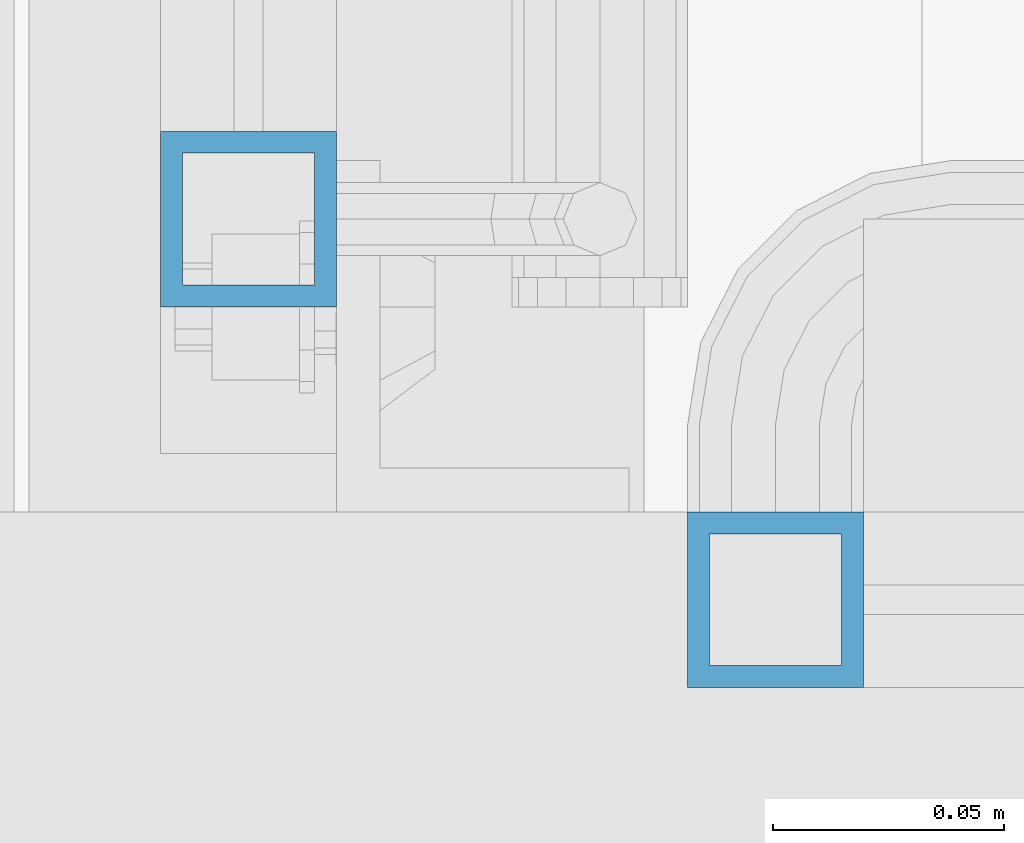
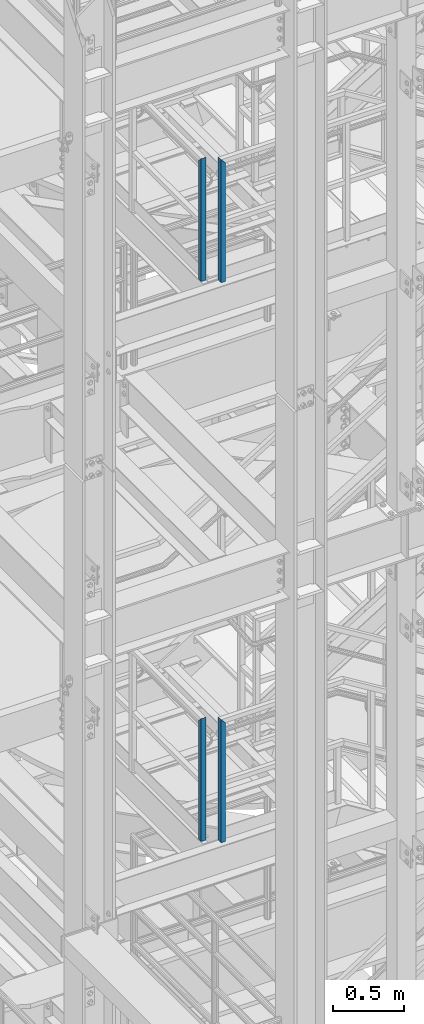
# One storey, part 566 of 1876: 4 columns, 4 elements without a shape of their own.
"""IFC2X3 building model written with IfcOpenShell, lengths in millimetres."""

from ifc_helpers import new_model, si_unit, frame, origin_with_axes, place, context, subcontext, project, spatial, faceted_brep, material, type_object, element, aggregate, save


model = new_model("IFC2X3")

# Units and contexts
model_context = context("Model", 3, precision=1e-05, world=origin_with_axes())
body_context = subcontext(model_context, "Body", "Model", "MODEL_VIEW")
ifc_project = project(units=[si_unit("LENGTHUNIT", "METRE", prefix="MILLI"), si_unit("AREAUNIT", "SQUARE_METRE"), si_unit("VOLUMEUNIT", "CUBIC_METRE"), si_unit("MASSUNIT", "GRAM", prefix="KILO"), si_unit("TIMEUNIT", "SECOND"), si_unit("PLANEANGLEUNIT", "RADIAN"), si_unit("SOLIDANGLEUNIT", "STERADIAN"), si_unit("THERMODYNAMICTEMPERATUREUNIT", "DEGREE_CELSIUS"), si_unit("LUMINOUSINTENSITYUNIT", "LUMEN")], contexts=[model_context])

# Site, building, storey
site_placement = place(None, origin_with_axes())
site = spatial("IfcSite", under=ifc_project, at=site_placement, CompositionType="ELEMENT")
building_placement = place(site_placement, origin_with_axes())
building = spatial("IfcBuilding", under=site, at=building_placement, Name="Undefined", CompositionType="ELEMENT")
storey_placement = place(building_placement, origin_with_axes())
storey = spatial("IfcBuildingStorey", under=building, at=storey_placement, Name="Undefined", CompositionType="ELEMENT", Elevation=0.0)

# Assembly, column
assembly_1_placement = place(storey_placement, origin_with_axes())
assembly_1 = element("IfcElementAssembly", 1, at=assembly_1_placement, inside=storey, Name="RAIL", AssemblyPlace="NOTDEFINED", PredefinedType="RIGID_FRAME")
ifc_material = material()
column_type = type_object("IfcColumnType", Name="HSS1-1/2X1-1/2X3/16", PredefinedType="NOTDEFINED")
column_1_placement = place(assembly_1_placement, frame((1085.85000034225, -6819.90000114826, 10766.4249999981), z_axis=(0.0, 1.0, 0.0), x_axis=(0.0, 0.0, 1.0)))
column_1 = element("IfcColumn", 2, at=column_1_placement, type_object=column_type, material=ifc_material, Name="POST", ObjectType="HSS1-1/2X1-1/2X3/16", context=body_context, shape_type="Brep", body=[
    faceted_brep([(0.0, 14.2874994260001, -14.2874994260001), (0.0, -14.2874994260001, -14.2874994260001), (1055.687499426, -14.2874994260001, -14.2874994260001), (1055.687499426, 14.2874994260001, -14.2874994260001), (0.0, -14.2874994260001, 14.2874994260001), (1027.112500574, -14.2874994260001, 14.2874994260001), (0.0, 14.2874994260001, 14.2874994260001), (1027.112500574, 14.2874994260001, 14.2874994260001), (0.0, 19.0499992349996, -19.0499992350001), (0.0, 19.0499992349996, 19.0499992349996), (1022.350000765, 19.0499992349996, 19.0499992349996), (1060.449999235, 19.0499992349996, -19.0499992349996), (0.0, -19.0499992349996, 19.0499992349996), (1022.350000765, -19.0499992349996, 19.0499992349996), (0.0, -19.0499992349996, -19.0499992350001), (1060.449999235, -19.0499992349996, -19.0499992349996)], [[[0, 1, 2, 3]], [[1, 4, 5, 2]], [[4, 6, 7, 5]], [[6, 0, 3, 7]], [[8, 9, 10, 11]], [[9, 12, 13, 10]], [[12, 14, 15, 13]], [[14, 8, 11, 15]], [[13, 15, 11, 10], [5, 7, 3, 2]], [[14, 12, 9, 8], [6, 4, 1, 0]]]),
])
aggregate(assembly_1, [column_1])

assembly_2_placement = place(storey_placement, origin_with_axes())
assembly_2 = element("IfcElementAssembly", 3, at=assembly_2_placement, inside=storey, Name="RAIL", AssemblyPlace="NOTDEFINED", PredefinedType="RIGID_FRAME")
column_2_placement = place(assembly_2_placement, frame((1200.15000079814, -6902.45000114554, 10766.4249989601), z_axis=(1.0, 0.0, 0.0), x_axis=(0.0, 0.0, 1.0)))
column_2 = element("IfcColumn", 4, at=column_2_placement, type_object=column_type, material=ifc_material, Name="POST", ObjectType="HSS1-1/2X1-1/2X3/16", context=body_context, shape_type="Brep", body=[
    faceted_brep([(0.0, 14.2874994260001, -14.2874994260001), (0.0, -14.2874994260001, -14.2874994260001), (1055.687499426, -14.2874994260001, -14.2874994260001), (1055.687499426, 14.2874994260001, -14.2874994260001), (0.0, -14.2874994260001, 14.2874994260001), (1027.112500574, -14.2874994260001, 14.2874994260001), (0.0, 14.2874994260001, 14.2874994260001), (1027.112500574, 14.2874994260001, 14.2874994260001), (0.0, 19.0499992349996, -19.0499992350001), (0.0, 19.0499992349996, 19.0499992349996), (1022.350000765, 19.0499992349996, 19.0499992349996), (1060.449999235, 19.0499992349996, -19.0499992349996), (0.0, -19.0499992349996, 19.0499992349996), (1022.350000765, -19.0499992349996, 19.0499992349996), (0.0, -19.0499992349996, -19.0499992350001), (1060.449999235, -19.0499992349996, -19.0499992349996)], [[[0, 1, 2, 3]], [[1, 4, 5, 2]], [[4, 6, 7, 5]], [[6, 0, 3, 7]], [[8, 9, 10, 11]], [[9, 12, 13, 10]], [[12, 14, 15, 13]], [[14, 8, 11, 15]], [[13, 15, 11, 10], [5, 7, 3, 2]], [[14, 12, 9, 8], [6, 4, 1, 0]]]),
])
aggregate(assembly_2, [column_2])

assembly_3_placement = place(storey_placement, origin_with_axes())
assembly_3 = element("IfcElementAssembly", 5, at=assembly_3_placement, inside=storey, Name="RAIL", AssemblyPlace="NOTDEFINED", PredefinedType="RIGID_FRAME")
column_3_placement = place(assembly_3_placement, frame((1200.1500011458, -6902.45000113218, 15594.776851636), z_axis=(1.0, 0.0, 0.0), x_axis=(0.0, 0.0, 1.0)))
column_3 = element("IfcColumn", 6, at=column_3_placement, type_object=column_type, material=ifc_material, Name="POST", ObjectType="HSS1-1/2X1-1/2X3/16", context=body_context, shape_type="Brep", body=[
    faceted_brep([(0.0, 14.2874994260001, -14.2874994260001), (0.0, -14.2874994260001, -14.2874994260001), (1055.68766311193, -14.2874994260001, -14.2874994260001), (1055.68766311193, 14.2874994260001, -14.2874994260001), (0.0, -14.2874994260001, 14.2874994260001), (1027.11266421952, -14.2874994260001, 14.2874994260001), (0.0, 14.2874994260001, 14.2874994260001), (1027.11266421952, 14.2874994260001, 14.2874994260001), (0.0, 19.0499992349996, -19.0499992350001), (0.0, 19.0499992349996, 19.0499992349996), (1022.35016440378, 19.0499992349996, 19.0499992350001), (1060.45016292766, 19.0499992349996, -19.0499992350001), (0.0, -19.0499992349996, 19.0499992349996), (1022.35016440378, -19.0499992349996, 19.0499992350001), (0.0, -19.0499992349996, -19.0499992350001), (1060.45016292766, -19.0499992349996, -19.0499992350001)], [[[0, 1, 2, 3]], [[1, 4, 5, 2]], [[4, 6, 7, 5]], [[6, 0, 3, 7]], [[8, 9, 10, 11]], [[9, 12, 13, 10]], [[12, 14, 15, 13]], [[14, 8, 11, 15]], [[13, 15, 11, 10], [5, 7, 3, 2]], [[14, 12, 9, 8], [6, 4, 1, 0]]]),
])
aggregate(assembly_3, [column_3])

assembly_4_placement = place(storey_placement, origin_with_axes())
assembly_4 = element("IfcElementAssembly", 7, at=assembly_4_placement, inside=storey, Name="RAIL", AssemblyPlace="NOTDEFINED", PredefinedType="RIGID_FRAME")
column_4_placement = place(assembly_4_placement, frame((1085.84999999374, -6819.90000114876, 15594.776851748), z_axis=(0.0, 1.0, 0.0), x_axis=(0.0, 0.0, 1.0)))
column_4 = element("IfcColumn", 8, at=column_4_placement, type_object=column_type, material=ifc_material, Name="POST", ObjectType="HSS1-1/2X1-1/2X3/16", context=body_context, shape_type="Brep", body=[
    faceted_brep([(0.0, 14.2874994260001, -14.2874994260001), (0.0, -14.2874994260001, -14.2874994260001), (1055.687499426, -14.2874994260001, -14.2874994260001), (1055.687499426, 14.2874994260001, -14.2874994260001), (0.0, -14.2874994260001, 14.2874994260001), (1027.112500574, -14.2874994260001, 14.2874994260001), (0.0, 14.2874994260001, 14.2874994260001), (1027.112500574, 14.2874994260001, 14.2874994260001), (0.0, 19.0499992349996, -19.0499992350001), (0.0, 19.0499992349996, 19.0499992349996), (1022.350000765, 19.0499992349996, 19.0499992349996), (1060.449999235, 19.0499992349996, -19.0499992349996), (0.0, -19.0499992349996, 19.0499992349996), (1022.350000765, -19.0499992349996, 19.0499992349996), (0.0, -19.0499992349996, -19.0499992350001), (1060.449999235, -19.0499992349996, -19.0499992349996)], [[[0, 1, 2, 3]], [[1, 4, 5, 2]], [[4, 6, 7, 5]], [[6, 0, 3, 7]], [[8, 9, 10, 11]], [[9, 12, 13, 10]], [[12, 14, 15, 13]], [[14, 8, 11, 15]], [[13, 15, 11, 10], [5, 7, 3, 2]], [[14, 12, 9, 8], [6, 4, 1, 0]]]),
])
aggregate(assembly_4, [column_4])

save(model, "model.ifc")
